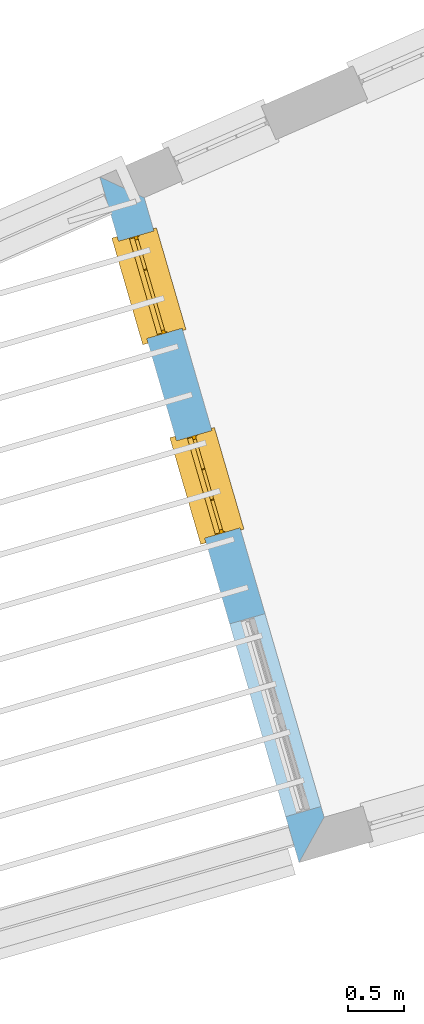
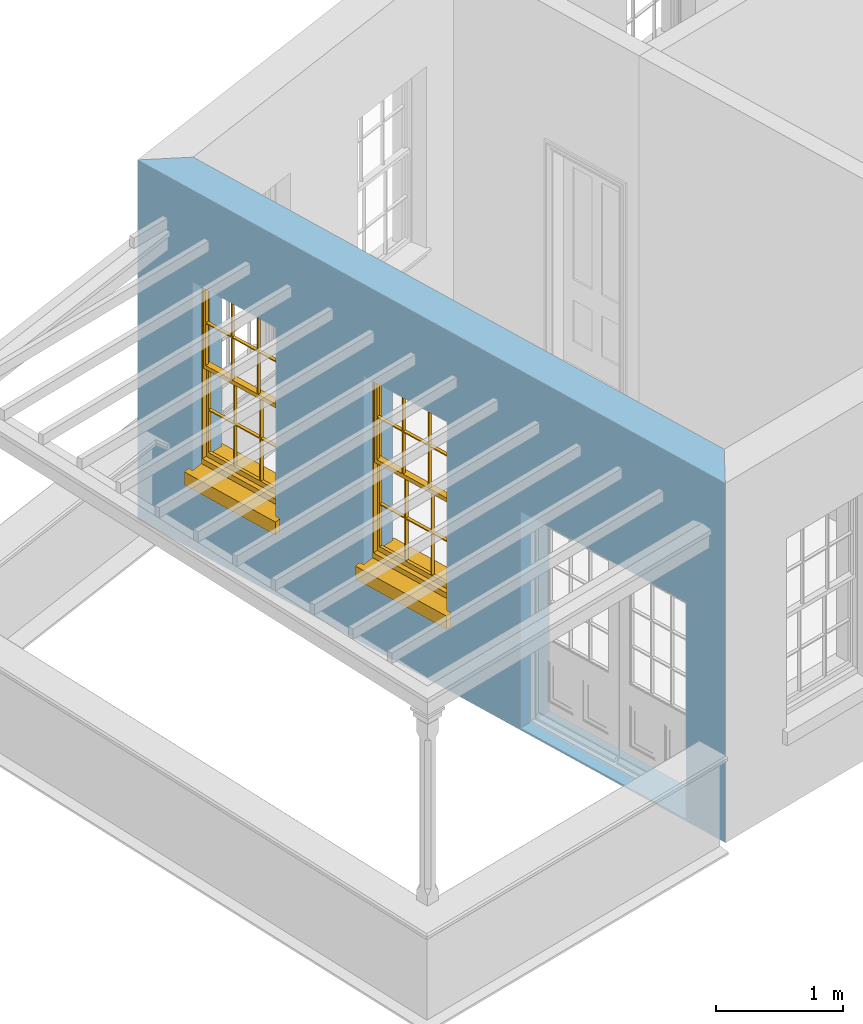
# One storey, part 2 of 11: 2 windows, 3 openings, plus 1 element that does not belong to this part.
"""IFC2X3 building model written with IfcOpenShell, lengths in metres."""

from ifc_helpers import new_model, si_unit, frame, origin, place, context, subcontext, project, spatial, polyline, outline, extrude, faceted_brep, material, layer, layer_set, layer_usage, element, fill, save


model = new_model("IFC2X3")

# Units and contexts
model_context = context("Model", 3, world=origin())
body_context = subcontext(model_context, "Body", "Model", "MODEL_VIEW")
ifc_project = project(units=[si_unit("PLANEANGLEUNIT", "RADIAN"), si_unit("MASSUNIT", "GRAM", prefix="KILO"), si_unit("FORCEUNIT", "NEWTON", prefix="KILO"), si_unit("LENGTHUNIT", "METRE")], contexts=[model_context])

# Site, building, storey
site_placement = place(None, origin())
site = spatial("IfcSite", under=ifc_project, at=site_placement, CompositionType="ELEMENT")
building_placement = place(None, origin())
building = spatial("IfcBuilding", under=site, at=building_placement, Name="Building plot-15", CompositionType="ELEMENT")
storey_placement = place(None, frame((0.0, 0.0, 7.6)))
storey = spatial("IfcBuildingStorey", under=building, at=storey_placement, Name="Floor 1", CompositionType="ELEMENT", Elevation=7.6)

# Wall, openings, windows
ifc_material = material(Name="Masonry")
ifc_layer = layer(ifc_material, 0.33, ventilated=False)
ifc_layer_set = layer_set([ifc_layer], Name="My Wall")
ifc_layer_usage = layer_usage(ifc_layer_set, "AXIS2", "NEGATIVE", 0.08)
wall_placement = place(storey_placement, origin())
wall = element("IfcWallStandardCase", 1, at=wall_placement, inside=storey, material=ifc_layer_usage, Name="exterior", context=body_context, shape_type="SweptSolid", body=[
    extrude(outline(polyline([(85.6873979783644, 56.0228656256528), (85.2898260322487, 56.2086132391335), (87.0751399602823, 50.0606585087336), (87.3002897494389, 50.4686684405552), (85.6873979783644, 56.0228656256528)])), origin(), (0.0, 0.0, 1.0), 3.45),
])
opening_1_placement = place(storey_placement, frame((0.0, 0.0, 0.75)))
opening_1 = element("IfcOpeningElement", 2, at=opening_1_placement, cuts=wall, Name="Opening", ObjectType="Opening", context=body_context, shape_type="SweptSolid", body=[
    extrude(outline(polyline([(85.4569058524119, 55.6332527075221), (85.7106786931988, 54.7593537744188), (86.0275870975109, 54.8513812881108), (85.773814256724, 55.725280221214), (85.4569058524119, 55.6332527075221)])), origin(), (0.0, 0.0, 1.0), 1.82),
])
opening_2_placement = place(storey_placement, frame((0.0, 0.0, 0.75)))
opening_2 = element("IfcOpeningElement", 3, at=opening_2_placement, cuts=wall, Name="Opening", ObjectType="Opening", context=body_context, shape_type="SweptSolid", body=[
    extrude(outline(polyline([(85.9765909320635, 53.8436512858375), (86.2303637728504, 52.9697523527342), (86.5472721771625, 53.0617798664262), (86.2934993363756, 53.9356787995294), (85.9765909320635, 53.8436512858375)])), origin(), (0.0, 0.0, 1.0), 1.82),
])
opening_3_placement = place(storey_placement, frame((0.0, 0.0, 0.0199999999999996)))
element("IfcOpeningElement", 4, at=opening_3_placement, cuts=wall, Name="Opening", ObjectType="Opening", context=body_context, shape_type="SweptSolid", body=[
    extrude(outline(polyline([(86.45346077574, 52.2014895544017), (86.9554290322415, 50.4728982581536), (87.2723374365537, 50.5649257718456), (86.7703691800521, 52.2935170680937), (86.45346077574, 52.2014895544017)])), origin(), (0.0, 0.0, 1.0), 2.08),
])
window_1_placement = place(storey_placement, frame((85.6969879768908, 55.7029705209251, 0.75), z_axis=(0.0, 0.0, 1.0), x_axis=(0.253772840786908, -0.87389893310322, 0.0)))
window_1 = element("IfcWindow", 5, at=window_1_placement, inside=storey, Name="living outside window", OverallHeight=1.82, OverallWidth=0.91, context=body_context, shape_type="Brep", held_by="IfcProductRepresentation", body=[
    faceted_brep([(0.033125, -0.105, 0.975209), (0.01, -0.105, 0.975209), (0.033125, -0.105, 1.376042), (0.876875, -0.105, 0.975209), (0.876875, -0.105, 1.376042), (0.9, -0.105, 0.975209), (0.876875, -0.105, 1.386042), (0.876875, -0.105, 1.786875), (0.9, -0.105, 1.81), (0.033125, -0.105, 1.786875), (0.033125, -0.105, 1.386042), (0.01, -0.105, 1.81), (0.876875, -0.135, 1.376042), (0.876875, -0.135, 0.975209), (0.9, -0.135, 0.937083), (0.033125, -0.135, 1.786875), (0.01, -0.135, 1.81), (0.033125, -0.135, 1.386042), (0.01, -0.135, 0.937083), (0.033125, -0.135, 0.975209), (0.033125, -0.135, 1.376042), (0.876875, -0.135, 1.786875), (0.876875, -0.135, 1.386042), (0.9, -0.135, 1.81), (0.033125, -0.105, 0.937083), (0.01, -0.105, 0.937083), (0.033125, -0.105, 0.53625), (0.876875, -0.105, 0.937083), (0.876875, -0.105, 0.53625), (0.9, -0.105, 0.937083), (0.876875, -0.105, 0.52625), (0.876875, -0.105, 0.125417), (0.9, -0.105, 0.077167), (0.033125, -0.105, 0.125417), (0.033125, -0.105, 0.52625), (0.01, -0.105, 0.077167), (-0.0425, -0.25, 0.01), (-0.0425, -0.3, 0.001667), (0.0, -0.25, 0.01), (0.9525, -0.25, 0.01), (0.91, -0.25, 0.01), (0.9525, -0.3, 0.001667), (-0.02, 0.08, 0.077167), (0.0, 0.08, 0.077167), (-0.02, 0.11, 0.077167), (0.0, -0.06, 0.077167), (0.01, -0.06, 0.077167), (0.91, -0.06, 0.077167), (0.91, 0.08, 0.077167), (0.9, -0.06, 0.077167), (0.93, 0.08, 0.077167), (0.93, 0.11, 0.077167), (0.01, -0.075, 0.975209), (0.9, -0.075, 0.975209), (0.876875, -0.075, 0.125417), (0.876875, -0.075, 0.52625), (0.9, -0.075, 0.077167), (0.876875, -0.075, 0.53625), (0.876875, -0.075, 0.937083), (0.033125, -0.075, 0.125417), (0.01, -0.075, 0.077167), (0.033125, -0.075, 0.52625), (0.033125, -0.075, 0.937083), (0.033125, -0.075, 0.53625), (-0.02, 0.08, 0.052167), (-0.02, 0.11, 0.052167), (0.93, 0.11, 0.052167), (0.93, 0.08, 0.052167), (0.91, 0.08, 0.052167), (0.0, 0.08, 0.052167), (0.91, -0.15, 0.026667), (0.0, -0.15, 0.026667), (-0.0425, -0.3, -0.123333), (0.9525, -0.3, -0.123333), (-0.0425, -0.25, -0.123333), (0.9525, -0.25, -0.123333), (0.01, -0.06, 1.81), (0.9, -0.06, 1.81), (0.0, -0.06, 1.82), (0.91, -0.06, 1.82), (0.01, -0.15, 0.077167), (0.9, -0.15, 0.077167), (0.592292, -0.105, 0.125417), (0.592292, -0.075, 0.125417), (0.317708, -0.075, 0.125417), (0.317708, -0.105, 0.125417), (0.592292, -0.105, 0.53625), (0.317708, -0.105, 0.53625), (0.317708, -0.105, 0.52625), (0.592292, -0.105, 0.52625), (0.592292, -0.075, 0.53625), (0.317708, -0.075, 0.53625), (0.592292, -0.135, 1.386042), (0.592292, -0.105, 1.386042), (0.317708, -0.105, 1.386042), (0.317708, -0.135, 1.386042), (0.317708, -0.135, 1.376042), (0.592292, -0.135, 1.376042), (0.317708, -0.105, 1.376042), (0.592292, -0.105, 1.376042), (0.602292, -0.135, 1.376042), (0.592292, -0.135, 0.975209), (0.602292, -0.135, 0.975209), (0.602292, -0.105, 0.975209), (0.592292, -0.105, 0.975209), (0.602292, -0.105, 1.376042), (0.602292, -0.075, 0.53625), (0.602292, -0.105, 0.53625), (0.317708, -0.075, 0.52625), (0.307708, -0.075, 0.125417), (0.307708, -0.075, 0.52625), (0.602292, -0.075, 0.52625), (0.602292, -0.075, 0.125417), (0.592292, -0.075, 0.52625), (0.307708, -0.075, 0.53625), (0.317708, -0.075, 0.937083), (0.307708, -0.075, 0.937083), (0.602292, -0.075, 0.937083), (0.592292, -0.075, 0.937083), (0.307708, -0.105, 0.52625), (0.307708, -0.105, 0.125417), (0.307708, -0.105, 0.53625), (0.307708, -0.105, 0.937083), (0.592292, -0.105, 0.937083), (0.317708, -0.105, 0.937083), (0.602292, -0.105, 0.937083), (0.602292, -0.105, 0.52625), (0.602292, -0.105, 0.125417), (0.307708, -0.135, 1.386042), (0.307708, -0.135, 1.376042), (0.307708, -0.135, 0.975209), (0.317708, -0.135, 0.975209), (0.317708, -0.135, 1.786875), (0.307708, -0.135, 1.786875), (0.602292, -0.135, 1.786875), (0.592292, -0.135, 1.786875), (0.602292, -0.135, 1.386042), (0.602292, -0.105, 1.386042), (0.307708, -0.105, 1.386042), (0.307708, -0.105, 1.786875), (0.317708, -0.105, 1.786875), (0.592292, -0.105, 1.786875), (0.602292, -0.105, 1.786875), (0.307708, -0.105, 1.376042), (0.317708, -0.105, 0.975209), (0.307708, -0.105, 0.975209), (0.91, -0.15, 1.82), (0.9, -0.15, 1.81), (0.01, -0.15, 1.81), (0.0, -0.15, 1.82), (0.91, -0.25, 0.0), (0.0, -0.25, 0.0), (0.91, 0.08, 0.0), (0.0, 0.08, 0.0)], [[[0, 1, 2]], [[3, 4, 5]], [[6, 7, 8]], [[9, 10, 11]], [[12, 13, 14]], [[15, 16, 17]], [[18, 19, 20]], [[21, 22, 23]], [[24, 25, 26]], [[27, 28, 29]], [[30, 31, 32]], [[33, 34, 35]], [[14, 27, 29]], [[25, 24, 18]], [[36, 37, 38]], [[39, 40, 41]], [[42, 43, 44]], [[45, 46, 43]], [[47, 48, 49]], [[50, 51, 48]], [[1, 0, 52]], [[5, 53, 3]], [[54, 55, 56]], [[57, 58, 53]], [[59, 60, 61]], [[62, 63, 52]], [[48, 43, 46, 49]], [[51, 44, 43, 48]], [[64, 42, 44, 65]], [[65, 44, 51, 66]], [[66, 51, 50, 67]], [[65, 66, 68, 69]], [[60, 56, 49, 46]], [[70, 71, 38, 40]], [[37, 41, 40, 38]], [[37, 72, 73, 41]], [[74, 75, 73, 72]], [[8, 11, 76, 77]], [[76, 78, 79, 77]], [[32, 35, 80, 81]], [[81, 80, 71, 70]], [[82, 83, 84, 85]], [[86, 87, 88, 89]], [[86, 90, 91, 87]], [[92, 93, 94, 95]], [[92, 95, 96, 97]], [[96, 98, 99, 97]], [[100, 97, 101, 102]], [[103, 104, 99, 105]], [[97, 99, 104, 101]], [[102, 103, 105, 100]], [[28, 57, 106, 107]], [[108, 84, 109, 110]], [[111, 112, 83, 113]], [[114, 110, 61, 63]], [[90, 113, 108, 91]], [[115, 91, 114, 116]], [[117, 106, 90, 118]], [[111, 106, 57, 55]], [[119, 110, 109, 120]], [[34, 61, 110, 119]], [[89, 113, 83, 82]], [[88, 108, 113, 89]], [[85, 84, 108, 88]], [[121, 114, 63, 26]], [[122, 116, 114, 121]], [[123, 118, 90, 86]], [[87, 91, 115, 124]], [[107, 106, 117, 125]], [[126, 111, 55, 30]], [[127, 112, 111, 126]], [[126, 30, 28, 107]], [[88, 119, 120, 85]], [[126, 89, 82, 127]], [[125, 123, 86, 107]], [[121, 26, 34, 119]], [[124, 122, 121, 87]], [[128, 17, 20, 129]], [[96, 129, 130, 131]], [[132, 133, 128, 95]], [[134, 135, 92, 136]], [[100, 12, 22, 136]], [[137, 6, 4, 105]], [[94, 138, 139, 140]], [[137, 93, 141, 142]], [[99, 98, 94, 93]], [[143, 2, 10, 138]], [[144, 145, 143, 98]], [[129, 143, 145, 130]], [[20, 2, 143, 129]], [[131, 144, 98, 96]], [[128, 138, 10, 17]], [[133, 139, 138, 128]], [[135, 141, 93, 92]], [[95, 94, 140, 132]], [[22, 6, 137, 136]], [[136, 137, 142, 134]], [[100, 105, 4, 12]], [[107, 86, 89, 126]], [[106, 111, 113, 90]], [[91, 108, 110, 114]], [[87, 121, 119, 88]], [[97, 100, 136, 92]], [[129, 96, 95, 128]], [[98, 143, 138, 94]], [[105, 99, 93, 137]], [[131, 101, 104, 144]], [[124, 115, 118, 123]], [[132, 140, 141, 135]], [[120, 109, 59, 33]], [[15, 9, 139, 133]], [[134, 142, 7, 21]], [[31, 54, 112, 127]], [[36, 74, 72, 37]], [[39, 41, 73, 75]], [[18, 14, 101, 131]], [[23, 16, 132, 135]], [[83, 56, 60, 84]], [[52, 53, 118, 115]], [[53, 52, 144, 104]], [[11, 8, 141, 140]], [[14, 18, 124, 123]], [[2, 1, 11, 10]], [[8, 5, 4, 6]], [[57, 53, 56, 55]], [[60, 52, 63, 61]], [[26, 25, 35, 34]], [[32, 29, 28, 30]], [[14, 23, 22, 12]], [[18, 20, 17, 16]], [[19, 0, 2, 20]], [[17, 10, 9, 15]], [[12, 4, 3, 13]], [[21, 7, 6, 22]], [[27, 58, 57, 28]], [[30, 55, 54, 31]], [[33, 59, 61, 34]], [[26, 63, 62, 24]], [[5, 8, 77, 53]], [[76, 11, 1, 52]], [[46, 45, 78, 76]], [[49, 77, 79, 47]], [[70, 146, 147, 81]], [[71, 80, 148, 149]], [[19, 130, 145, 0]], [[102, 13, 3, 103]], [[116, 122, 24, 62]], [[29, 32, 81, 14]], [[80, 35, 25, 18]], [[60, 46, 76, 52]], [[77, 49, 56, 53]], [[23, 14, 81, 147]], [[16, 148, 80, 18]], [[35, 85, 120]], [[120, 33, 35]], [[127, 82, 32]], [[32, 31, 127]], [[32, 82, 85, 35]], [[102, 101, 14]], [[14, 13, 102]], [[18, 131, 130]], [[130, 19, 18]], [[134, 21, 23]], [[23, 135, 134]], [[16, 15, 133]], [[133, 132, 16]], [[11, 140, 139]], [[139, 9, 11]], [[142, 141, 8]], [[8, 7, 142]], [[23, 147, 148, 16]], [[146, 149, 148, 147]], [[52, 115, 116]], [[116, 62, 52]], [[118, 53, 117]], [[58, 117, 53]], [[27, 125, 117, 58]], [[56, 83, 112]], [[112, 54, 56]], [[109, 84, 60]], [[60, 59, 109]], [[125, 27, 14]], [[14, 123, 125]], [[122, 124, 18]], [[18, 24, 122]], [[145, 144, 52]], [[52, 0, 145]], [[103, 3, 53]], [[53, 104, 103]], [[79, 78, 149, 146]], [[78, 45, 71, 149]], [[146, 70, 47, 79]], [[150, 75, 74, 151]], [[68, 66, 67]], [[48, 68, 67, 50]], [[69, 64, 65]], [[42, 64, 69, 43]], [[69, 68, 152, 153]], [[70, 68, 48, 47]], [[150, 152, 68, 70]], [[43, 69, 71, 45]], [[69, 153, 151, 71]], [[152, 150, 151, 153]], [[38, 151, 74, 36]], [[71, 151, 38]], [[39, 75, 150, 40]], [[40, 150, 70]]]),
])
fill(opening_1, window_1)
window_2_placement = place(storey_placement, frame((86.2166730565424, 53.9133690992404, 0.75), z_axis=(0.0, 0.0, 1.0), x_axis=(0.253772840786908, -0.87389893310322, 0.0)))
window_2 = element("IfcWindow", 6, at=window_2_placement, inside=storey, Name="living outside window", OverallHeight=1.82, OverallWidth=0.91, context=body_context, shape_type="Brep", held_by="IfcProductRepresentation", body=[
    faceted_brep([(0.033125, -0.105, 0.975209), (0.01, -0.105, 0.975209), (0.033125, -0.105, 1.376042), (0.876875, -0.105, 0.975209), (0.876875, -0.105, 1.376042), (0.9, -0.105, 0.975209), (0.876875, -0.105, 1.386042), (0.876875, -0.105, 1.786875), (0.9, -0.105, 1.81), (0.033125, -0.105, 1.786875), (0.033125, -0.105, 1.386042), (0.01, -0.105, 1.81), (0.876875, -0.135, 1.376042), (0.876875, -0.135, 0.975209), (0.9, -0.135, 0.937083), (0.033125, -0.135, 1.786875), (0.01, -0.135, 1.81), (0.033125, -0.135, 1.386042), (0.01, -0.135, 0.937083), (0.033125, -0.135, 0.975209), (0.033125, -0.135, 1.376042), (0.876875, -0.135, 1.786875), (0.876875, -0.135, 1.386042), (0.9, -0.135, 1.81), (0.033125, -0.105, 0.937083), (0.01, -0.105, 0.937083), (0.033125, -0.105, 0.53625), (0.876875, -0.105, 0.937083), (0.876875, -0.105, 0.53625), (0.9, -0.105, 0.937083), (0.876875, -0.105, 0.52625), (0.876875, -0.105, 0.125417), (0.9, -0.105, 0.077167), (0.033125, -0.105, 0.125417), (0.033125, -0.105, 0.52625), (0.01, -0.105, 0.077167), (-0.0425, -0.25, 0.01), (-0.0425, -0.3, 0.001667), (0.0, -0.25, 0.01), (0.9525, -0.25, 0.01), (0.91, -0.25, 0.01), (0.9525, -0.3, 0.001667), (-0.02, 0.08, 0.077167), (0.0, 0.08, 0.077167), (-0.02, 0.11, 0.077167), (0.0, -0.06, 0.077167), (0.01, -0.06, 0.077167), (0.91, -0.06, 0.077167), (0.91, 0.08, 0.077167), (0.9, -0.06, 0.077167), (0.93, 0.08, 0.077167), (0.93, 0.11, 0.077167), (0.01, -0.075, 0.975209), (0.9, -0.075, 0.975209), (0.876875, -0.075, 0.125417), (0.876875, -0.075, 0.52625), (0.9, -0.075, 0.077167), (0.876875, -0.075, 0.53625), (0.876875, -0.075, 0.937083), (0.033125, -0.075, 0.125417), (0.01, -0.075, 0.077167), (0.033125, -0.075, 0.52625), (0.033125, -0.075, 0.937083), (0.033125, -0.075, 0.53625), (-0.02, 0.08, 0.052167), (-0.02, 0.11, 0.052167), (0.93, 0.11, 0.052167), (0.93, 0.08, 0.052167), (0.91, 0.08, 0.052167), (0.0, 0.08, 0.052167), (0.91, -0.15, 0.026667), (0.0, -0.15, 0.026667), (-0.0425, -0.3, -0.123333), (0.9525, -0.3, -0.123333), (-0.0425, -0.25, -0.123333), (0.9525, -0.25, -0.123333), (0.01, -0.06, 1.81), (0.9, -0.06, 1.81), (0.0, -0.06, 1.82), (0.91, -0.06, 1.82), (0.01, -0.15, 0.077167), (0.9, -0.15, 0.077167), (0.592292, -0.105, 0.125417), (0.592292, -0.075, 0.125417), (0.317708, -0.075, 0.125417), (0.317708, -0.105, 0.125417), (0.592292, -0.105, 0.53625), (0.317708, -0.105, 0.53625), (0.317708, -0.105, 0.52625), (0.592292, -0.105, 0.52625), (0.592292, -0.075, 0.53625), (0.317708, -0.075, 0.53625), (0.592292, -0.135, 1.386042), (0.592292, -0.105, 1.386042), (0.317708, -0.105, 1.386042), (0.317708, -0.135, 1.386042), (0.317708, -0.135, 1.376042), (0.592292, -0.135, 1.376042), (0.317708, -0.105, 1.376042), (0.592292, -0.105, 1.376042), (0.602292, -0.135, 1.376042), (0.592292, -0.135, 0.975209), (0.602292, -0.135, 0.975209), (0.602292, -0.105, 0.975209), (0.592292, -0.105, 0.975209), (0.602292, -0.105, 1.376042), (0.602292, -0.075, 0.53625), (0.602292, -0.105, 0.53625), (0.317708, -0.075, 0.52625), (0.307708, -0.075, 0.125417), (0.307708, -0.075, 0.52625), (0.602292, -0.075, 0.52625), (0.602292, -0.075, 0.125417), (0.592292, -0.075, 0.52625), (0.307708, -0.075, 0.53625), (0.317708, -0.075, 0.937083), (0.307708, -0.075, 0.937083), (0.602292, -0.075, 0.937083), (0.592292, -0.075, 0.937083), (0.307708, -0.105, 0.52625), (0.307708, -0.105, 0.125417), (0.307708, -0.105, 0.53625), (0.307708, -0.105, 0.937083), (0.592292, -0.105, 0.937083), (0.317708, -0.105, 0.937083), (0.602292, -0.105, 0.937083), (0.602292, -0.105, 0.52625), (0.602292, -0.105, 0.125417), (0.307708, -0.135, 1.386042), (0.307708, -0.135, 1.376042), (0.307708, -0.135, 0.975209), (0.317708, -0.135, 0.975209), (0.317708, -0.135, 1.786875), (0.307708, -0.135, 1.786875), (0.602292, -0.135, 1.786875), (0.592292, -0.135, 1.786875), (0.602292, -0.135, 1.386042), (0.602292, -0.105, 1.386042), (0.307708, -0.105, 1.386042), (0.307708, -0.105, 1.786875), (0.317708, -0.105, 1.786875), (0.592292, -0.105, 1.786875), (0.602292, -0.105, 1.786875), (0.307708, -0.105, 1.376042), (0.317708, -0.105, 0.975209), (0.307708, -0.105, 0.975209), (0.91, -0.15, 1.82), (0.9, -0.15, 1.81), (0.01, -0.15, 1.81), (0.0, -0.15, 1.82), (0.91, -0.25, 0.0), (0.0, -0.25, 0.0), (0.91, 0.08, 0.0), (0.0, 0.08, 0.0)], [[[0, 1, 2]], [[3, 4, 5]], [[6, 7, 8]], [[9, 10, 11]], [[12, 13, 14]], [[15, 16, 17]], [[18, 19, 20]], [[21, 22, 23]], [[24, 25, 26]], [[27, 28, 29]], [[30, 31, 32]], [[33, 34, 35]], [[14, 27, 29]], [[25, 24, 18]], [[36, 37, 38]], [[39, 40, 41]], [[42, 43, 44]], [[45, 46, 43]], [[47, 48, 49]], [[50, 51, 48]], [[1, 0, 52]], [[5, 53, 3]], [[54, 55, 56]], [[57, 58, 53]], [[59, 60, 61]], [[62, 63, 52]], [[48, 43, 46, 49]], [[51, 44, 43, 48]], [[64, 42, 44, 65]], [[65, 44, 51, 66]], [[66, 51, 50, 67]], [[65, 66, 68, 69]], [[60, 56, 49, 46]], [[70, 71, 38, 40]], [[37, 41, 40, 38]], [[37, 72, 73, 41]], [[74, 75, 73, 72]], [[8, 11, 76, 77]], [[76, 78, 79, 77]], [[32, 35, 80, 81]], [[81, 80, 71, 70]], [[82, 83, 84, 85]], [[86, 87, 88, 89]], [[86, 90, 91, 87]], [[92, 93, 94, 95]], [[92, 95, 96, 97]], [[96, 98, 99, 97]], [[100, 97, 101, 102]], [[103, 104, 99, 105]], [[97, 99, 104, 101]], [[102, 103, 105, 100]], [[28, 57, 106, 107]], [[108, 84, 109, 110]], [[111, 112, 83, 113]], [[114, 110, 61, 63]], [[90, 113, 108, 91]], [[115, 91, 114, 116]], [[117, 106, 90, 118]], [[111, 106, 57, 55]], [[119, 110, 109, 120]], [[34, 61, 110, 119]], [[89, 113, 83, 82]], [[88, 108, 113, 89]], [[85, 84, 108, 88]], [[121, 114, 63, 26]], [[122, 116, 114, 121]], [[123, 118, 90, 86]], [[87, 91, 115, 124]], [[107, 106, 117, 125]], [[126, 111, 55, 30]], [[127, 112, 111, 126]], [[126, 30, 28, 107]], [[88, 119, 120, 85]], [[126, 89, 82, 127]], [[125, 123, 86, 107]], [[121, 26, 34, 119]], [[124, 122, 121, 87]], [[128, 17, 20, 129]], [[96, 129, 130, 131]], [[132, 133, 128, 95]], [[134, 135, 92, 136]], [[100, 12, 22, 136]], [[137, 6, 4, 105]], [[94, 138, 139, 140]], [[137, 93, 141, 142]], [[99, 98, 94, 93]], [[143, 2, 10, 138]], [[144, 145, 143, 98]], [[129, 143, 145, 130]], [[20, 2, 143, 129]], [[131, 144, 98, 96]], [[128, 138, 10, 17]], [[133, 139, 138, 128]], [[135, 141, 93, 92]], [[95, 94, 140, 132]], [[22, 6, 137, 136]], [[136, 137, 142, 134]], [[100, 105, 4, 12]], [[107, 86, 89, 126]], [[106, 111, 113, 90]], [[91, 108, 110, 114]], [[87, 121, 119, 88]], [[97, 100, 136, 92]], [[129, 96, 95, 128]], [[98, 143, 138, 94]], [[105, 99, 93, 137]], [[131, 101, 104, 144]], [[124, 115, 118, 123]], [[132, 140, 141, 135]], [[120, 109, 59, 33]], [[15, 9, 139, 133]], [[134, 142, 7, 21]], [[31, 54, 112, 127]], [[36, 74, 72, 37]], [[39, 41, 73, 75]], [[18, 14, 101, 131]], [[23, 16, 132, 135]], [[83, 56, 60, 84]], [[52, 53, 118, 115]], [[53, 52, 144, 104]], [[11, 8, 141, 140]], [[14, 18, 124, 123]], [[2, 1, 11, 10]], [[8, 5, 4, 6]], [[57, 53, 56, 55]], [[60, 52, 63, 61]], [[26, 25, 35, 34]], [[32, 29, 28, 30]], [[14, 23, 22, 12]], [[18, 20, 17, 16]], [[19, 0, 2, 20]], [[17, 10, 9, 15]], [[12, 4, 3, 13]], [[21, 7, 6, 22]], [[27, 58, 57, 28]], [[30, 55, 54, 31]], [[33, 59, 61, 34]], [[26, 63, 62, 24]], [[5, 8, 77, 53]], [[76, 11, 1, 52]], [[46, 45, 78, 76]], [[49, 77, 79, 47]], [[70, 146, 147, 81]], [[71, 80, 148, 149]], [[19, 130, 145, 0]], [[102, 13, 3, 103]], [[116, 122, 24, 62]], [[29, 32, 81, 14]], [[80, 35, 25, 18]], [[60, 46, 76, 52]], [[77, 49, 56, 53]], [[23, 14, 81, 147]], [[16, 148, 80, 18]], [[35, 85, 120]], [[120, 33, 35]], [[127, 82, 32]], [[32, 31, 127]], [[32, 82, 85, 35]], [[102, 101, 14]], [[14, 13, 102]], [[18, 131, 130]], [[130, 19, 18]], [[134, 21, 23]], [[23, 135, 134]], [[16, 15, 133]], [[133, 132, 16]], [[11, 140, 139]], [[139, 9, 11]], [[142, 141, 8]], [[8, 7, 142]], [[23, 147, 148, 16]], [[146, 149, 148, 147]], [[52, 115, 116]], [[116, 62, 52]], [[118, 53, 117]], [[58, 117, 53]], [[27, 125, 117, 58]], [[56, 83, 112]], [[112, 54, 56]], [[109, 84, 60]], [[60, 59, 109]], [[125, 27, 14]], [[14, 123, 125]], [[122, 124, 18]], [[18, 24, 122]], [[145, 144, 52]], [[52, 0, 145]], [[103, 3, 53]], [[53, 104, 103]], [[79, 78, 149, 146]], [[78, 45, 71, 149]], [[146, 70, 47, 79]], [[150, 75, 74, 151]], [[68, 66, 67]], [[48, 68, 67, 50]], [[69, 64, 65]], [[42, 64, 69, 43]], [[69, 68, 152, 153]], [[70, 68, 48, 47]], [[150, 152, 68, 70]], [[43, 69, 71, 45]], [[69, 153, 151, 71]], [[152, 150, 151, 153]], [[38, 151, 74, 36]], [[71, 151, 38]], [[39, 75, 150, 40]], [[40, 150, 70]]]),
])
fill(opening_2, window_2)

save(model, "model.ifc")
